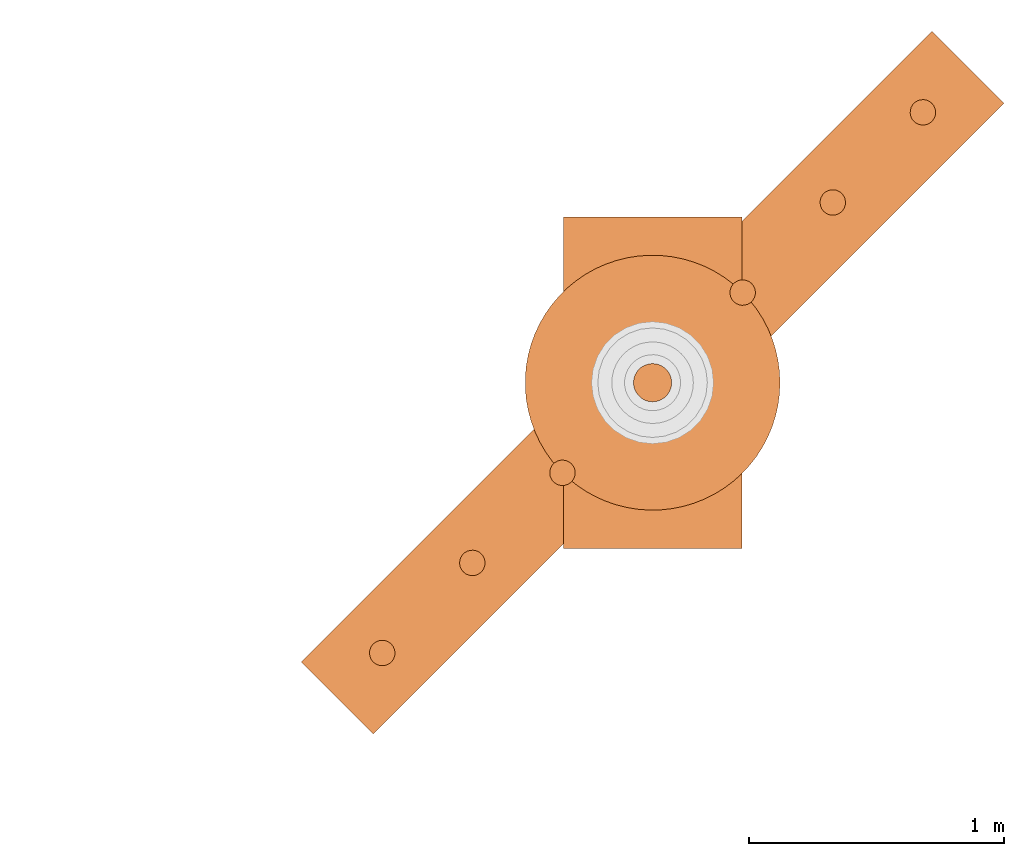
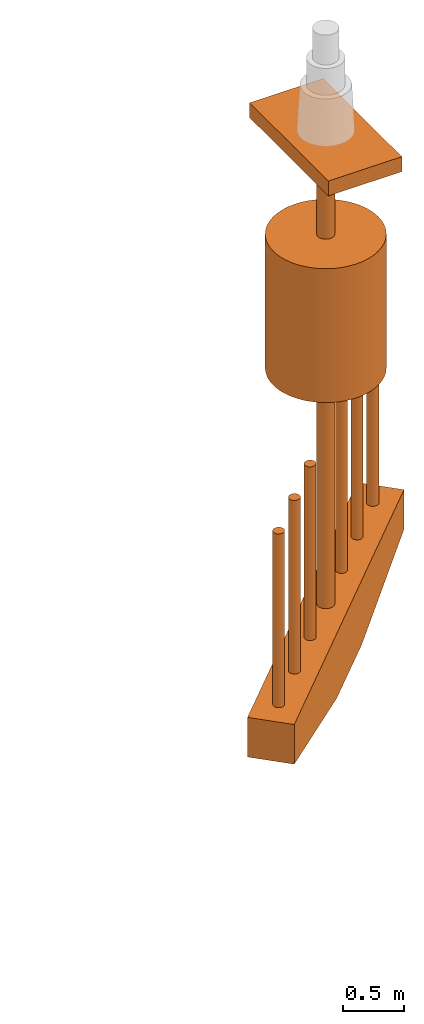
# One storey, part 2 of 5: 10 proxies.
"""IFC2X3 building model written with IfcOpenShell, lengths in millimetres."""

import ifcopenshell
import ifcopenshell.guid

model = None  # the IFC model being written
_history = None  # IfcOwnerHistory: only IFC2X3 demands one
_inside = {}  # id of a spatial element -> (the spatial element, [elements in it])
_under = {}  # id of a project, library or spatial element -> (it, [spatial elements below it])
_declared = {}  # id of a project -> (the project, [libraries it declares])
_typed = {}  # id of a type object -> (the type object, [elements of that type])
_made_of = {}  # id of a material, layer set ... -> (it, [elements and type objects made of it])


def new_model(schema):
    """Start an empty IFC model of exactly this schema.

    Asked for "IFC4X3", IfcOpenShell would pick the latest addendum, in which some entities
    have other attributes; the version numbers below select the first issue.
    IFC2X3 requires an IfcOwnerHistory on every rooted entity: one is made here for all.
    """
    global model, _history
    if schema == "IFC4X3":
        model = ifcopenshell.file(schema_version=(4, 3, 0, 0))
    else:
        model = ifcopenshell.file(schema=schema)
    _inside.clear()
    _under.clear()
    _declared.clear()
    _typed.clear()
    _made_of.clear()
    _history = None
    if model.schema == "IFC2X3":
        org = make("IfcOrganization", Name="unknown")
        user = make(
            "IfcPersonAndOrganization",
            ThePerson=make("IfcPerson", FamilyName="unknown"),
            TheOrganization=org,
        )
        app = make(
            "IfcApplication",
            ApplicationDeveloper=org,
            Version="unknown",
            ApplicationFullName="unknown",
            ApplicationIdentifier="unknown",
        )
        _history = make(
            "IfcOwnerHistory",
            OwningUser=user,
            OwningApplication=app,
            ChangeAction="ADDED",
            CreationDate=0,
        )
    return model


def make(cls, **values):
    """One entity of the class cls with the attributes given. An attribute that is None is left unset."""
    return model.create_entity(
        cls, **{name: value for name, value in values.items() if value is not None}
    )


def entity(cls, *values):
    """Any entity or typed value of the class cls, its attributes in the order of the schema. None: left unset."""
    e = model.create_entity(cls)
    for i, value in enumerate(values):
        if value is not None:
            e[i] = value
    return e


def rooted(cls, **values):
    """An entity with a GlobalId (a new one), such as an element, a storey or a relation."""
    return make(cls, GlobalId=ifcopenshell.guid.new(), OwnerHistory=_history, **values)


def si_unit(unit_type, name, prefix=None):
    """IfcSIUnit, for example si_unit("LENGTHUNIT", "METRE", prefix="MILLI")."""
    return make("IfcSIUnit", UnitType=unit_type, Prefix=prefix, Name=name)


def converted_unit(unit_type, name, factor, base, dimensions=None, offset=None):
    """IfcConversionBasedUnit, such as the inch: factor (a typed value) times the base unit."""
    return make(
        "IfcConversionBasedUnit"
        if offset is None
        else "IfcConversionBasedUnitWithOffset",
        ConversionOffset=offset,
        Dimensions=None
        if dimensions is None
        else entity("IfcDimensionalExponents", *dimensions),
        UnitType=unit_type,
        Name=name,
        ConversionFactor=make(
            "IfcMeasureWithUnit", ValueComponent=factor, UnitComponent=base
        ),
    )


def assignment(units):
    """IfcUnitAssignment: the units of a project."""
    return None if units is None else make("IfcUnitAssignment", Units=units)


def point(xyz):
    """IfcCartesianPoint."""
    return None if xyz is None else make("IfcCartesianPoint", Coordinates=xyz)


def direction(xyz):
    """IfcDirection."""
    return None if xyz is None else make("IfcDirection", DirectionRatios=xyz)


def frame(location, z_axis=None, x_axis=None):
    """IfcAxis2Placement3D, a coordinate frame: its origin and axes. An axis left out is left unset."""
    return make(
        "IfcAxis2Placement3D",
        Location=point(location),
        Axis=direction(z_axis),
        RefDirection=direction(x_axis),
    )


def frame_2d(location, x_axis=None):
    """IfcAxis2Placement2D, a coordinate frame in the plane: its origin and x axis."""
    return make(
        "IfcAxis2Placement2D", Location=point(location), RefDirection=direction(x_axis)
    )


def origin_with_axes():
    """The frame at (0, 0, 0) with the z axis (0, 0, 1) and the x axis (1, 0, 0) written out."""
    return frame((0.0, 0.0, 0.0), z_axis=(0.0, 0.0, 1.0), x_axis=(1.0, 0.0, 0.0))


def origin_2d_with_axis():
    """The frame at (0, 0) in the plane with the x axis (1, 0) written out."""
    return frame_2d((0.0, 0.0), x_axis=(1.0, 0.0))


def place(relative_to, where):
    """IfcLocalPlacement: puts the frame where relative to a parent placement (None: the world)."""
    return make(
        "IfcLocalPlacement", PlacementRelTo=relative_to, RelativePlacement=where
    )


def context(
    kind, dimensions, precision=None, world=None, true_north=None, identifier=None
):
    """IfcGeometricRepresentationContext, for example the 3D "Model" context."""
    return make(
        "IfcGeometricRepresentationContext",
        ContextIdentifier=identifier,
        ContextType=kind,
        CoordinateSpaceDimension=dimensions,
        Precision=precision,
        WorldCoordinateSystem=world,
        TrueNorth=true_north,
    )


def project(units=None, contexts=None):
    """IfcProject with its units and contexts."""
    return rooted(
        "IfcProject",
        Name="project",
        RepresentationContexts=contexts,
        UnitsInContext=assignment(units),
    )


def spatial(cls, under=None, at=None, **own):
    """A site, building, storey or space (cls), placed at a placement, below another one or the project."""
    s = rooted(cls, ObjectPlacement=at, **own)
    if under is not None:
        _under.setdefault(under.id(), (under, []))[1].append(s)
    return s


def polyline(points):
    """IfcPolyline through the points."""
    return make("IfcPolyline", Points=[point(p) for p in points])


def profile(cls, at=None, kind="AREA", **sizes):
    """A parametric profile (cls). Its sizes go by their IFC names, for example OverallWidth=200.0."""
    return make(cls, ProfileType=kind, Position=at, **sizes)


def rectangle(**sizes):
    """IfcRectangleProfileDef."""
    return profile("IfcRectangleProfileDef", **sizes)


def circle(**sizes):
    """IfcCircleProfileDef."""
    return profile("IfcCircleProfileDef", **sizes)


def outline(outer, holes=None, kind="AREA"):
    """IfcArbitraryClosedProfileDef: a profile drawn as a closed curve; with holes, ...WithVoids."""
    if holes is None:
        return make("IfcArbitraryClosedProfileDef", ProfileType=kind, OuterCurve=outer)
    return make(
        "IfcArbitraryProfileDefWithVoids",
        ProfileType=kind,
        OuterCurve=outer,
        InnerCurves=holes,
    )


def extrude(swept, where, along, depth):
    """IfcExtrudedAreaSolid: the profile swept, set in the frame where, extruded along a direction by depth."""
    return make(
        "IfcExtrudedAreaSolid",
        SweptArea=swept,
        Position=where,
        ExtrudedDirection=direction(along),
        Depth=depth,
    )


def shape(context_of_items, identifier, shape_type, items):
    """IfcShapeRepresentation: the items that make up one representation, for example the "Body"."""
    return make(
        "IfcShapeRepresentation",
        ContextOfItems=context_of_items,
        RepresentationIdentifier=identifier,
        RepresentationType=shape_type,
        Items=items,
    )


def source(mapping_origin, context_of_items, identifier, shape_type, items):
    """IfcRepresentationMap: a shape defined once, which mapped items show again and again."""
    return make(
        "IfcRepresentationMap",
        MappingOrigin=mapping_origin,
        MappedRepresentation=shape(context_of_items, identifier, shape_type, items),
    )


def transform(
    local_origin,
    x_axis=None,
    y_axis=None,
    z_axis=None,
    scale=None,
    scale2=None,
    scale3=None,
    uniform=True,
):
    """IfcCartesianTransformationOperator3D, or its non-uniform kind. x_axis, y_axis, z_axis: its Axis1, 2, 3."""
    if uniform:
        return make(
            "IfcCartesianTransformationOperator3D",
            Axis1=direction(x_axis),
            Axis2=direction(y_axis),
            LocalOrigin=point(local_origin),
            Scale=scale,
            Axis3=direction(z_axis),
        )
    return make(
        "IfcCartesianTransformationOperator3DnonUniform",
        Axis1=direction(x_axis),
        Axis2=direction(y_axis),
        LocalOrigin=point(local_origin),
        Scale=scale,
        Axis3=direction(z_axis),
        Scale2=scale2,
        Scale3=scale3,
    )


def mapped(mapping_source, mapping_target):
    """IfcMappedItem: shows the shape of a source again, moved by a transform."""
    return make(
        "IfcMappedItem", MappingSource=mapping_source, MappingTarget=mapping_target
    )


def made_of(thing, what):
    """Note that an element or type object is made of a material, layer set ...; save() writes the relation."""
    if what is not None:
        _made_of.setdefault(what.id(), (what, []))[1].append(thing)
    return thing


def element(
    cls,
    number,
    at=None,
    inside=None,
    cuts=None,
    type_object=None,
    material=None,
    context=None,
    identifier="Body",
    shape_type=None,
    held_by="IfcProductDefinitionShape",
    body=None,
    shapes=None,
    **own,
):
    """One element of the class cls, such as IfcWall. Its Tag is "e" and its number.

    at: its placement. inside: the storey or other place that contains it. cuts: it is an
    opening in that element (IfcRelVoidsElement). A single representation is given by context,
    identifier, shape_type and body (its items); several are given by shapes. held_by: the class
    of the entity that holds the representations. save() writes the other relations.
    """
    e = rooted(cls, Tag="e%d" % number, ObjectPlacement=at, **own)
    if body is not None:
        shapes = [shape(context, identifier, shape_type, body)]
    if shapes is not None:
        e.Representation = make(held_by, Representations=shapes)
    if inside is not None:
        _inside.setdefault(inside.id(), (inside, []))[1].append(e)
    if cuts is not None:
        rooted(
            "IfcRelVoidsElement", RelatingBuildingElement=cuts, RelatedOpeningElement=e
        )
    if type_object is not None:
        _typed.setdefault(type_object.id(), (type_object, []))[1].append(e)
    return made_of(e, material)


def aggregate(whole, parts):
    """IfcRelAggregates: a whole, such as a stair, and the parts it consists of."""
    return rooted("IfcRelAggregates", RelatingObject=whole, RelatedObjects=parts)


def save(model, path):
    """Write the relations noted so far, then the file.

    IfcRelAggregates (storeys below a building ...), IfcRelContainedInSpatialStructure (elements
    in a storey), IfcRelDefinesByType, IfcRelAssociatesMaterial and IfcRelDeclares: one each for
    every whole, place, type object, material and project.
    """
    for whole, parts in _under.values():
        aggregate(whole, parts)
    for where, things in _inside.values():
        rooted(
            "IfcRelContainedInSpatialStructure",
            RelatedElements=things,
            RelatingStructure=where,
        )
    for kind, things in _typed.values():
        rooted("IfcRelDefinesByType", RelatedObjects=things, RelatingType=kind)
    for what, things in _made_of.values():
        rooted("IfcRelAssociatesMaterial", RelatedObjects=things, RelatingMaterial=what)
    for by, libraries in _declared.values():
        rooted("IfcRelDeclares", RelatingContext=by, RelatedDefinitions=libraries)
    model.write(path)


model = new_model("IFC2X3")

# Units and contexts
model_context = context("Model", 3, precision=1e-05, world=origin_with_axes(), true_north=direction((0.0, 1.0)))
ifc_project = project(units=[si_unit("LENGTHUNIT", "METRE", prefix="MILLI"), si_unit("AREAUNIT", "SQUARE_METRE"), si_unit("VOLUMEUNIT", "CUBIC_METRE"), converted_unit("PLANEANGLEUNIT", "DEGREE", entity("IfcPlaneAngleMeasure", 0.017453293), si_unit("PLANEANGLEUNIT", "RADIAN"), dimensions=[0, 0, 0, 0, 0, 0, 0]), si_unit("SOLIDANGLEUNIT", "STERADIAN"), si_unit("MASSUNIT", "GRAM"), si_unit("TIMEUNIT", "SECOND"), si_unit("THERMODYNAMICTEMPERATUREUNIT", "DEGREE_CELSIUS"), si_unit("LUMINOUSINTENSITYUNIT", "LUMEN")], contexts=[model_context])

# Site, building, storey
site_placement = place(None, origin_with_axes())
site = spatial("IfcSite", under=ifc_project, at=site_placement, CompositionType="ELEMENT")
building_placement = place(site_placement, origin_with_axes())
building = spatial("IfcBuilding", under=site, at=building_placement, Name="Default Building", CompositionType="ELEMENT")
storey_placement = place(building_placement, frame((0.0, 0.0, 8000.0), z_axis=(0.0, 0.0, 1.0), x_axis=(1.0, 0.0, 0.0)))
storey = spatial("IfcBuildingStorey", under=building, at=storey_placement, Name="2FL", CompositionType="ELEMENT", Elevation=8000.0)

# Proxies
shared_shape_1 = source(origin_with_axes(), model_context, "Body", "SweptSolid", [
    extrude(rectangle(XDim=700.0, YDim=1300.0, at=origin_2d_with_axis()), origin_with_axes(), (0.0, 0.0, 1.0), 150.0),
])
proxy_1_placement = place(storey_placement, frame((53012.702942, 14305.649567, 4732.050808), z_axis=(0.0, 0.0, 1.0), x_axis=(1.0, 0.0, 0.0)))
element("IfcBuildingElementProxy", 1, at=proxy_1_placement, inside=storey, context=model_context, shape_type="MappedRepresentation", body=[
    mapped(shared_shape_1, transform((0.0, 0.0, 0.0))),
])
shared_shape_2 = source(origin_with_axes(), model_context, "Body", "SweptSolid", [
    extrude(circle(Radius=50.0, at=origin_2d_with_axis()), frame((0.0, 0.0, 0.0), z_axis=(0.0, 0.0, 1.0), x_axis=(1.0, -3.14012054206114e-16, 0.0)), (0.0, 0.0, 1.0), 1750.0),
])
proxy_2_placement = place(storey_placement, frame((51952.04277, 13244.989395, 107.050808), z_axis=(0.0, 0.0, 1.0), x_axis=(-0.707106781186546, -0.707106781186549, 0.0)))
element("IfcBuildingElementProxy", 2, at=proxy_2_placement, inside=storey, context=model_context, shape_type="MappedRepresentation", body=[
    mapped(shared_shape_2, transform((0.0, 0.0, 0.0))),
])
shared_shape_3 = source(origin_with_axes(), model_context, "Body", "SweptSolid", [
    extrude(circle(Radius=50.0, at=origin_2d_with_axis()), frame((0.0, 0.0, 0.0), z_axis=(0.0, 0.0, 1.0), x_axis=(1.0, -3.14012054206114e-16, 0.0)), (0.0, 0.0, 1.0), 1750.0),
])
proxy_3_placement = place(storey_placement, frame((52659.149551, 13952.096176, 107.050808), z_axis=(0.0, 0.0, 1.0), x_axis=(-0.707106781186546, -0.707106781186549, 0.0)))
element("IfcBuildingElementProxy", 3, at=proxy_3_placement, inside=storey, context=model_context, shape_type="MappedRepresentation", body=[
    mapped(shared_shape_3, transform((0.0, 0.0, 0.0))),
])
shared_shape_4 = source(origin_with_axes(), model_context, "Body", "SweptSolid", [
    extrude(circle(Radius=50.0, at=origin_2d_with_axis()), frame((0.0, 0.0, 0.0), z_axis=(0.0, 0.0, 1.0), x_axis=(1.0, 6.28024108412228e-16, 0.0)), (0.0, 0.0, 1.0), 1750.0),
])
proxy_4_placement = place(storey_placement, frame((53719.809723, 15012.756348, 107.050808), z_axis=(0.0, 0.0, 1.0), x_axis=(0.707106781186548, 0.707106781186547, 0.0)))
element("IfcBuildingElementProxy", 4, at=proxy_4_placement, inside=storey, context=model_context, shape_type="MappedRepresentation", body=[
    mapped(shared_shape_4, transform((0.0, 0.0, 0.0))),
])
shared_shape_5 = source(origin_with_axes(), model_context, "Body", "SweptSolid", [
    extrude(circle(Radius=50.0, at=origin_2d_with_axis()), frame((0.0, 0.0, 0.0), z_axis=(0.0, 0.0, 1.0), x_axis=(1.0, 6.28024108412228e-16, 0.0)), (0.0, 0.0, 1.0), 1750.0),
])
proxy_5_placement = place(storey_placement, frame((53366.256332, 14659.202957, 107.050808), z_axis=(0.0, 0.0, 1.0), x_axis=(0.707106781186548, 0.707106781186547, 0.0)))
element("IfcBuildingElementProxy", 5, at=proxy_5_placement, inside=storey, context=model_context, shape_type="MappedRepresentation", body=[
    mapped(shared_shape_5, transform((0.0, 0.0, 0.0))),
])
shared_shape_6 = source(origin_with_axes(), model_context, "Body", "SweptSolid", [
    extrude(circle(Radius=500.0, at=origin_2d_with_axis()), origin_with_axes(), (0.0, 0.0, 1.0), 1350.0),
])
proxy_6_placement = place(storey_placement, frame((53012.702942, 14305.649567, 2482.050808), z_axis=(0.0, 0.0, 1.0), x_axis=(1.0, 0.0, 0.0)))
element("IfcBuildingElementProxy", 6, at=proxy_6_placement, inside=storey, context=model_context, shape_type="MappedRepresentation", body=[
    mapped(shared_shape_6, transform((0.0, 0.0, 0.0))),
])
shared_shape_7 = source(origin_with_axes(), model_context, "Body", "SweptSolid", [
    extrude(outline(polyline([(-1750.0, 325.0), (-1750.0, -75.0), (-400.0, -325.0), (400.0, -325.0), (1750.0, -75.0), (1750.0, 325.0), (-1750.0, 325.0)])), frame((0.0, 0.0, 0.0), z_axis=(1.57019579630213e-16, 0.0, 1.0), x_axis=(1.0, 0.0, -1.57019579630213e-16)), (0.0, 0.0, 1.0), 399.999999999996),
])
proxy_7_placement = place(storey_placement, frame((52871.281586, 14447.070923, -217.949192), z_axis=(0.707106781186546, -0.707106781186549, 0.0), x_axis=(0.707106781186549, 0.707106781186546, 0.0)))
element("IfcBuildingElementProxy", 7, at=proxy_7_placement, inside=storey, context=model_context, shape_type="MappedRepresentation", body=[
    mapped(shared_shape_7, transform((0.0, 0.0, 0.0))),
])
shared_shape_8 = source(origin_with_axes(), model_context, "Body", "SweptSolid", [
    extrude(circle(Radius=75.0, at=origin_2d_with_axis()), origin_with_axes(), (0.0, 0.0, 1.0), 5275.0),
])
proxy_8_placement = place(storey_placement, frame((53012.702942, 14305.649567, -542.949192), z_axis=(0.0, 0.0, 1.0), x_axis=(1.0, 0.0, 0.0)))
element("IfcBuildingElementProxy", 8, at=proxy_8_placement, inside=storey, context=model_context, shape_type="MappedRepresentation", body=[
    mapped(shared_shape_8, transform((0.0, 0.0, 0.0))),
])
shared_shape_9 = source(origin_with_axes(), model_context, "Body", "SweptSolid", [
    extrude(circle(Radius=50.0, at=origin_2d_with_axis()), frame((0.0, 0.0, 0.0), z_axis=(0.0, 0.0, 1.0), x_axis=(1.0, -3.14012054206114e-16, 0.0)), (0.0, 0.0, 1.0), 1750.0),
])
proxy_9_placement = place(storey_placement, frame((52305.596161, 13598.542785, 107.050808), z_axis=(0.0, 0.0, 1.0), x_axis=(-0.707106781186546, -0.707106781186549, 0.0)))
element("IfcBuildingElementProxy", 9, at=proxy_9_placement, inside=storey, context=model_context, shape_type="MappedRepresentation", body=[
    mapped(shared_shape_9, transform((0.0, 0.0, 0.0))),
])
shared_shape_10 = source(origin_with_axes(), model_context, "Body", "SweptSolid", [
    extrude(circle(Radius=50.0, at=origin_2d_with_axis()), frame((0.0, 0.0, 0.0), z_axis=(0.0, 0.0, 1.0), x_axis=(1.0, 6.28024108412228e-16, 0.0)), (0.0, 0.0, 1.0), 1750.0),
])
proxy_10_placement = place(storey_placement, frame((54073.363114, 15366.309738, 107.050808), z_axis=(0.0, 0.0, 1.0), x_axis=(0.707106781186548, 0.707106781186547, 0.0)))
element("IfcBuildingElementProxy", 10, at=proxy_10_placement, inside=storey, context=model_context, shape_type="MappedRepresentation", body=[
    mapped(shared_shape_10, transform((0.0, 0.0, 0.0))),
])

save(model, "model.ifc")
